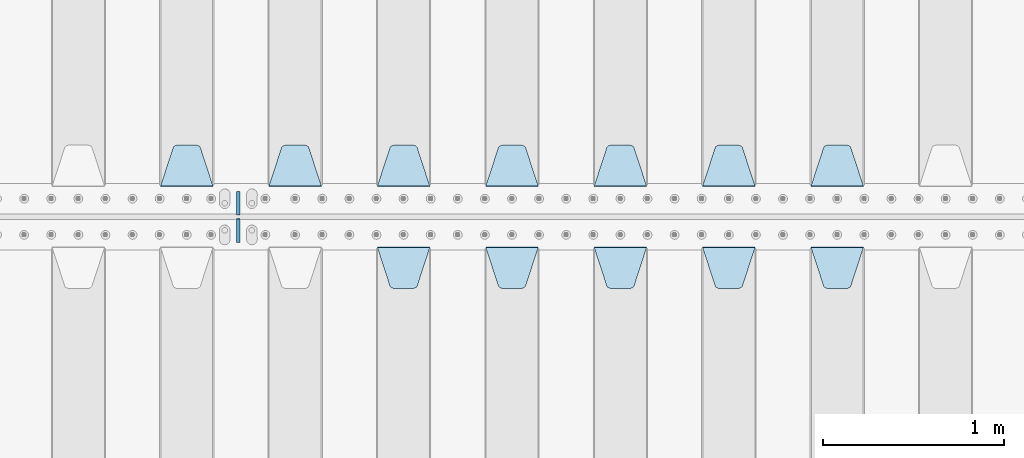
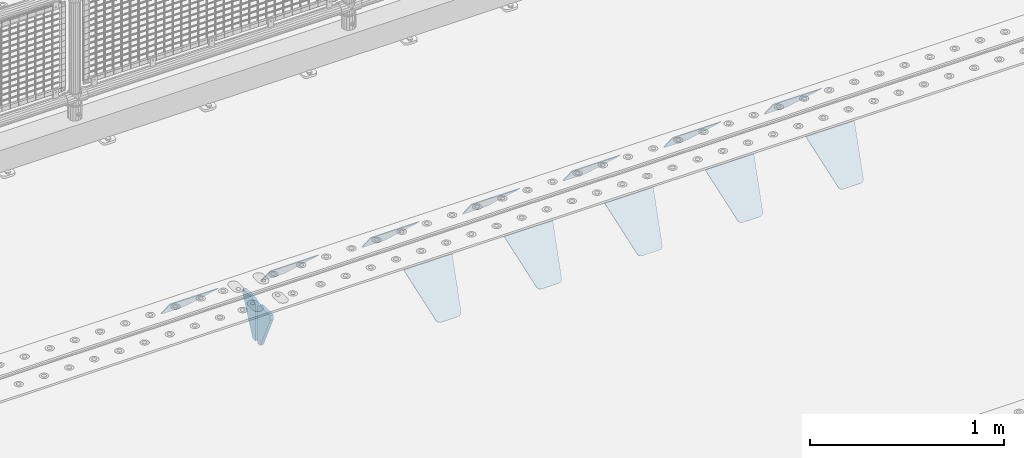
# One storey, part 226 of 270: 14 plates.
"""IFC2X3 building model written with IfcOpenShell, lengths in millimetres."""

from ifc_helpers import new_model, si_unit, frame, origin_with_axes, place, context, subcontext, project, spatial, faceted_brep, material, type_object, element, save


model = new_model("IFC2X3")

# Units and contexts
model_context = context("Model", 3, precision=1e-05, world=origin_with_axes())
body_context = subcontext(model_context, "Body", "Model", "MODEL_VIEW")
ifc_project = project(units=[si_unit("LENGTHUNIT", "METRE", prefix="MILLI"), si_unit("AREAUNIT", "SQUARE_METRE"), si_unit("VOLUMEUNIT", "CUBIC_METRE"), si_unit("MASSUNIT", "GRAM", prefix="KILO"), si_unit("TIMEUNIT", "SECOND"), si_unit("PLANEANGLEUNIT", "RADIAN"), si_unit("SOLIDANGLEUNIT", "STERADIAN"), si_unit("THERMODYNAMICTEMPERATUREUNIT", "DEGREE_CELSIUS"), si_unit("LUMINOUSINTENSITYUNIT", "LUMEN")], contexts=[model_context])

# Site, building, storey
site_placement = place(None, origin_with_axes())
site = spatial("IfcSite", under=ifc_project, at=site_placement, CompositionType="ELEMENT")
building_placement = place(site_placement, origin_with_axes())
building = spatial("IfcBuilding", under=site, at=building_placement, Name="Standard", CompositionType="ELEMENT")
storey_placement = place(building_placement, origin_with_axes())
storey = spatial("IfcBuildingStorey", under=building, at=storey_placement, Name="Undefined", CompositionType="ELEMENT", Elevation=0.0)

# Plates
ifc_material = material(Name="STEEL/S355N")
plate_type_1 = type_object("IfcPlateType", PredefinedType="NOTDEFINED")
plate_1_placement = place(storey_placement, frame((10745.0, -17831.767766953, -1.76776695296758), z_axis=(0.0, 0.707106781186547, -0.707106781186548), x_axis=(-1.0, 0.0, 0.0)))
element("IfcPlate", 1, at=plate_1_placement, inside=storey, type_object=plate_type_1, material=ifc_material, context=body_context, shape_type="Brep", body=[
    faceted_brep([(0.0, -2.5, 0.0), (69.345504679477, -2.5, 300.171731424831), (69.345504679477, 2.5, 300.171731424831), (0.0, 2.5, 0.0), (70.9274061199576, -2.5, 304.8974424154), (70.9274061199576, 2.5, 304.8974424154), (73.3818627772307, -2.49999999999818, 309.234538108527), (73.3818627772307, 2.50000000000182, 309.234538108527), (76.6187032999551, -2.5, 313.023683126103), (76.6187032999551, 2.5, 313.023683126103), (80.5190132704993, -2.5, 316.125672595372), (80.5190132704993, 2.50000000000182, 316.125672595372), (84.9395038596849, -2.49999999999818, 318.426546230476), (84.9395038596849, 2.5, 318.426546230476), (89.7177759439219, -2.49999999999818, 319.841774983275), (89.7177759439219, 2.50000000000182, 319.841774983275), (94.678286292652, -2.5, 320.319366455078), (94.678286292652, 2.5, 320.319366455078), (195.321713707348, -2.5, 320.319366455078), (195.321713707348, 2.5, 320.319366455078), (200.282224056078, -2.49999999999818, 319.841774983275), (200.282224056078, 2.50000000000182, 319.841774983275), (205.060496140315, -2.5, 318.426546230476), (205.060496140315, 2.5, 318.426546230476), (209.480986729501, -2.5, 316.12567259537), (209.480986729501, 2.50000000000182, 316.12567259537), (213.381296700045, -2.5, 313.023683126103), (213.381296700045, 2.5, 313.023683126103), (216.618137222769, -2.49999999999818, 309.234538108525), (216.618137222769, 2.50000000000182, 309.234538108527), (219.072593880042, -2.49999999999818, 304.897442415398), (219.072593880042, 2.50000000000182, 304.897442415397), (220.654495320523, -2.5, 300.171731424831), (220.654495320523, 2.5, 300.171731424831), (290.0, -2.49999999999818, 0.0), (290.0, 2.5, 0.0)], [[[0, 1, 2, 3]], [[1, 4, 5, 2]], [[4, 6, 7, 5]], [[6, 8, 9, 7]], [[8, 10, 11, 9]], [[10, 12, 13, 11]], [[12, 14, 15, 13]], [[14, 16, 17, 15]], [[16, 18, 19, 17]], [[18, 20, 21, 19]], [[20, 22, 23, 21]], [[22, 24, 25, 23]], [[24, 26, 27, 25]], [[26, 28, 29, 27]], [[28, 30, 31, 29]], [[30, 32, 33, 31]], [[32, 34, 35, 33]], [[34, 0, 3, 35]], [[5, 7, 9, 11, 13, 15, 17, 19, 21, 23, 25, 27, 29, 31, 33, 35, 3, 2]], [[34, 32, 30, 28, 26, 24, 22, 20, 18, 16, 14, 12, 10, 8, 6, 4, 1, 0]]]),
])
plate_2_placement = place(storey_placement, frame((10145.0, -17831.767766953, -1.76776695296758), z_axis=(0.0, 0.707106781186547, -0.707106781186548), x_axis=(-1.0, 0.0, 0.0)))
element("IfcPlate", 2, at=plate_2_placement, inside=storey, type_object=plate_type_1, material=ifc_material, context=body_context, shape_type="Brep", body=[
    faceted_brep([(0.0, -2.5, 0.0), (69.345504679477, -2.5, 300.171731424831), (69.345504679477, 2.5, 300.171731424831), (0.0, 2.5, 0.0), (70.9274061199576, -2.5, 304.8974424154), (70.9274061199576, 2.5, 304.8974424154), (73.3818627772307, -2.49999999999818, 309.234538108527), (73.3818627772307, 2.50000000000182, 309.234538108527), (76.6187032999551, -2.5, 313.023683126103), (76.6187032999551, 2.5, 313.023683126103), (80.5190132704993, -2.5, 316.125672595372), (80.5190132704993, 2.50000000000182, 316.125672595372), (84.9395038596849, -2.49999999999818, 318.426546230476), (84.9395038596849, 2.5, 318.426546230476), (89.7177759439219, -2.49999999999818, 319.841774983275), (89.7177759439219, 2.50000000000182, 319.841774983275), (94.678286292652, -2.5, 320.319366455078), (94.678286292652, 2.5, 320.319366455078), (195.321713707348, -2.5, 320.319366455078), (195.321713707348, 2.5, 320.319366455078), (200.282224056078, -2.49999999999818, 319.841774983275), (200.282224056078, 2.50000000000182, 319.841774983275), (205.060496140315, -2.5, 318.426546230476), (205.060496140315, 2.5, 318.426546230476), (209.480986729501, -2.5, 316.12567259537), (209.480986729501, 2.50000000000182, 316.12567259537), (213.381296700045, -2.5, 313.023683126103), (213.381296700045, 2.5, 313.023683126103), (216.618137222769, -2.49999999999818, 309.234538108525), (216.618137222769, 2.50000000000182, 309.234538108527), (219.072593880042, -2.49999999999818, 304.897442415398), (219.072593880042, 2.50000000000182, 304.897442415397), (220.654495320523, -2.5, 300.171731424831), (220.654495320523, 2.5, 300.171731424831), (290.0, -2.49999999999818, 0.0), (290.0, 2.5, 0.0)], [[[0, 1, 2, 3]], [[1, 4, 5, 2]], [[4, 6, 7, 5]], [[6, 8, 9, 7]], [[8, 10, 11, 9]], [[10, 12, 13, 11]], [[12, 14, 15, 13]], [[14, 16, 17, 15]], [[16, 18, 19, 17]], [[18, 20, 21, 19]], [[20, 22, 23, 21]], [[22, 24, 25, 23]], [[24, 26, 27, 25]], [[26, 28, 29, 27]], [[28, 30, 31, 29]], [[30, 32, 33, 31]], [[32, 34, 35, 33]], [[34, 0, 3, 35]], [[5, 7, 9, 11, 13, 15, 17, 19, 21, 23, 25, 27, 29, 31, 33, 35, 3, 2]], [[34, 32, 30, 28, 26, 24, 22, 20, 18, 16, 14, 12, 10, 8, 6, 4, 1, 0]]]),
])
plate_3_placement = place(storey_placement, frame((9545.0, -17831.767766953, -1.76776695296758), z_axis=(0.0, 0.707106781186547, -0.707106781186548), x_axis=(-1.0, 0.0, 0.0)))
element("IfcPlate", 3, at=plate_3_placement, inside=storey, type_object=plate_type_1, material=ifc_material, context=body_context, shape_type="Brep", body=[
    faceted_brep([(0.0, -2.5, 0.0), (69.345504679477, -2.5, 300.171731424831), (69.345504679477, 2.5, 300.171731424831), (0.0, 2.5, 0.0), (70.9274061199576, -2.5, 304.8974424154), (70.9274061199576, 2.5, 304.8974424154), (73.3818627772307, -2.49999999999818, 309.234538108527), (73.3818627772307, 2.50000000000182, 309.234538108527), (76.6187032999551, -2.5, 313.023683126103), (76.6187032999551, 2.5, 313.023683126103), (80.5190132704993, -2.5, 316.125672595372), (80.5190132704993, 2.50000000000182, 316.125672595372), (84.9395038596849, -2.49999999999818, 318.426546230476), (84.9395038596849, 2.5, 318.426546230476), (89.7177759439219, -2.49999999999818, 319.841774983275), (89.7177759439219, 2.50000000000182, 319.841774983275), (94.678286292652, -2.5, 320.319366455078), (94.678286292652, 2.5, 320.319366455078), (195.321713707348, -2.5, 320.319366455078), (195.321713707348, 2.5, 320.319366455078), (200.282224056078, -2.49999999999818, 319.841774983275), (200.282224056078, 2.50000000000182, 319.841774983275), (205.060496140315, -2.5, 318.426546230476), (205.060496140315, 2.5, 318.426546230476), (209.480986729501, -2.5, 316.12567259537), (209.480986729501, 2.50000000000182, 316.12567259537), (213.381296700045, -2.5, 313.023683126103), (213.381296700045, 2.5, 313.023683126103), (216.618137222769, -2.49999999999818, 309.234538108525), (216.618137222769, 2.50000000000182, 309.234538108527), (219.072593880042, -2.49999999999818, 304.897442415398), (219.072593880042, 2.50000000000182, 304.897442415397), (220.654495320523, -2.5, 300.171731424831), (220.654495320523, 2.5, 300.171731424831), (290.0, -2.49999999999818, 0.0), (290.0, 2.5, 0.0)], [[[0, 1, 2, 3]], [[1, 4, 5, 2]], [[4, 6, 7, 5]], [[6, 8, 9, 7]], [[8, 10, 11, 9]], [[10, 12, 13, 11]], [[12, 14, 15, 13]], [[14, 16, 17, 15]], [[16, 18, 19, 17]], [[18, 20, 21, 19]], [[20, 22, 23, 21]], [[22, 24, 25, 23]], [[24, 26, 27, 25]], [[26, 28, 29, 27]], [[28, 30, 31, 29]], [[30, 32, 33, 31]], [[32, 34, 35, 33]], [[34, 0, 3, 35]], [[5, 7, 9, 11, 13, 15, 17, 19, 21, 23, 25, 27, 29, 31, 33, 35, 3, 2]], [[34, 32, 30, 28, 26, 24, 22, 20, 18, 16, 14, 12, 10, 8, 6, 4, 1, 0]]]),
])
plate_4_placement = place(storey_placement, frame((8945.0, -17831.767766953, -1.76776695296758), z_axis=(0.0, 0.707106781186547, -0.707106781186548), x_axis=(-1.0, 0.0, 0.0)))
element("IfcPlate", 4, at=plate_4_placement, inside=storey, type_object=plate_type_1, material=ifc_material, context=body_context, shape_type="Brep", body=[
    faceted_brep([(0.0, -2.5, 0.0), (69.345504679477, -2.5, 300.171731424831), (69.345504679477, 2.5, 300.171731424831), (0.0, 2.5, 0.0), (70.9274061199576, -2.5, 304.8974424154), (70.9274061199576, 2.5, 304.8974424154), (73.3818627772307, -2.49999999999818, 309.234538108527), (73.3818627772307, 2.50000000000182, 309.234538108527), (76.6187032999551, -2.5, 313.023683126103), (76.6187032999551, 2.5, 313.023683126103), (80.5190132704993, -2.5, 316.125672595372), (80.5190132704993, 2.50000000000182, 316.125672595372), (84.9395038596849, -2.49999999999818, 318.426546230476), (84.9395038596849, 2.5, 318.426546230476), (89.7177759439219, -2.49999999999818, 319.841774983275), (89.7177759439219, 2.50000000000182, 319.841774983275), (94.678286292652, -2.5, 320.319366455078), (94.678286292652, 2.5, 320.319366455078), (195.321713707348, -2.5, 320.319366455078), (195.321713707348, 2.5, 320.319366455078), (200.282224056078, -2.49999999999818, 319.841774983275), (200.282224056078, 2.50000000000182, 319.841774983275), (205.060496140315, -2.5, 318.426546230476), (205.060496140315, 2.5, 318.426546230476), (209.480986729501, -2.5, 316.12567259537), (209.480986729501, 2.50000000000182, 316.12567259537), (213.381296700045, -2.5, 313.023683126103), (213.381296700045, 2.5, 313.023683126103), (216.618137222769, -2.49999999999818, 309.234538108525), (216.618137222769, 2.50000000000182, 309.234538108527), (219.072593880042, -2.49999999999818, 304.897442415398), (219.072593880042, 2.50000000000182, 304.897442415397), (220.654495320523, -2.5, 300.171731424831), (220.654495320523, 2.5, 300.171731424831), (290.0, -2.49999999999818, 0.0), (290.0, 2.5, 0.0)], [[[0, 1, 2, 3]], [[1, 4, 5, 2]], [[4, 6, 7, 5]], [[6, 8, 9, 7]], [[8, 10, 11, 9]], [[10, 12, 13, 11]], [[12, 14, 15, 13]], [[14, 16, 17, 15]], [[16, 18, 19, 17]], [[18, 20, 21, 19]], [[20, 22, 23, 21]], [[22, 24, 25, 23]], [[24, 26, 27, 25]], [[26, 28, 29, 27]], [[28, 30, 31, 29]], [[30, 32, 33, 31]], [[32, 34, 35, 33]], [[34, 0, 3, 35]], [[5, 7, 9, 11, 13, 15, 17, 19, 21, 23, 25, 27, 29, 31, 33, 35, 3, 2]], [[34, 32, 30, 28, 26, 24, 22, 20, 18, 16, 14, 12, 10, 8, 6, 4, 1, 0]]]),
])
plate_5_placement = place(storey_placement, frame((8345.0, -17831.767766953, -1.76776695296758), z_axis=(0.0, 0.707106781186547, -0.707106781186548), x_axis=(-1.0, 0.0, 0.0)))
element("IfcPlate", 5, at=plate_5_placement, inside=storey, type_object=plate_type_1, material=ifc_material, context=body_context, shape_type="Brep", body=[
    faceted_brep([(0.0, -2.5, 0.0), (69.345504679477, -2.5, 300.171731424831), (69.345504679477, 2.5, 300.171731424831), (0.0, 2.5, 0.0), (70.9274061199576, -2.5, 304.8974424154), (70.9274061199576, 2.5, 304.8974424154), (73.3818627772307, -2.49999999999818, 309.234538108527), (73.3818627772307, 2.50000000000182, 309.234538108527), (76.6187032999551, -2.5, 313.023683126103), (76.6187032999551, 2.5, 313.023683126103), (80.5190132704993, -2.5, 316.125672595372), (80.5190132704993, 2.50000000000182, 316.125672595372), (84.9395038596849, -2.49999999999818, 318.426546230476), (84.9395038596849, 2.5, 318.426546230476), (89.7177759439219, -2.49999999999818, 319.841774983275), (89.7177759439219, 2.50000000000182, 319.841774983275), (94.678286292652, -2.5, 320.319366455078), (94.678286292652, 2.5, 320.319366455078), (195.321713707348, -2.5, 320.319366455078), (195.321713707348, 2.5, 320.319366455078), (200.282224056078, -2.49999999999818, 319.841774983275), (200.282224056078, 2.50000000000182, 319.841774983275), (205.060496140315, -2.5, 318.426546230476), (205.060496140315, 2.5, 318.426546230476), (209.480986729501, -2.5, 316.12567259537), (209.480986729501, 2.50000000000182, 316.12567259537), (213.381296700045, -2.5, 313.023683126103), (213.381296700045, 2.5, 313.023683126103), (216.618137222769, -2.49999999999818, 309.234538108525), (216.618137222769, 2.50000000000182, 309.234538108527), (219.072593880042, -2.49999999999818, 304.897442415398), (219.072593880042, 2.50000000000182, 304.897442415397), (220.654495320523, -2.5, 300.171731424831), (220.654495320523, 2.5, 300.171731424831), (290.0, -2.49999999999818, 0.0), (290.0, 2.5, 0.0)], [[[0, 1, 2, 3]], [[1, 4, 5, 2]], [[4, 6, 7, 5]], [[6, 8, 9, 7]], [[8, 10, 11, 9]], [[10, 12, 13, 11]], [[12, 14, 15, 13]], [[14, 16, 17, 15]], [[16, 18, 19, 17]], [[18, 20, 21, 19]], [[20, 22, 23, 21]], [[22, 24, 25, 23]], [[24, 26, 27, 25]], [[26, 28, 29, 27]], [[28, 30, 31, 29]], [[30, 32, 33, 31]], [[32, 34, 35, 33]], [[34, 0, 3, 35]], [[5, 7, 9, 11, 13, 15, 17, 19, 21, 23, 25, 27, 29, 31, 33, 35, 3, 2]], [[34, 32, 30, 28, 26, 24, 22, 20, 18, 16, 14, 12, 10, 8, 6, 4, 1, 0]]]),
])
plate_6_placement = place(storey_placement, frame((7745.0, -17831.767766953, -1.76776695296758), z_axis=(0.0, 0.707106781186547, -0.707106781186548), x_axis=(-1.0, 0.0, 0.0)))
element("IfcPlate", 6, at=plate_6_placement, inside=storey, type_object=plate_type_1, material=ifc_material, context=body_context, shape_type="Brep", body=[
    faceted_brep([(0.0, -2.5, 0.0), (69.345504679477, -2.5, 300.171731424831), (69.345504679477, 2.5, 300.171731424831), (0.0, 2.5, 0.0), (70.9274061199576, -2.5, 304.8974424154), (70.9274061199576, 2.5, 304.8974424154), (73.3818627772307, -2.49999999999818, 309.234538108527), (73.3818627772307, 2.50000000000182, 309.234538108527), (76.6187032999551, -2.5, 313.023683126103), (76.6187032999551, 2.5, 313.023683126103), (80.5190132704993, -2.5, 316.125672595372), (80.5190132704993, 2.50000000000182, 316.125672595372), (84.9395038596849, -2.49999999999818, 318.426546230476), (84.9395038596849, 2.5, 318.426546230476), (89.7177759439219, -2.49999999999818, 319.841774983275), (89.7177759439219, 2.50000000000182, 319.841774983275), (94.678286292652, -2.5, 320.319366455078), (94.678286292652, 2.5, 320.319366455078), (195.321713707348, -2.5, 320.319366455078), (195.321713707348, 2.5, 320.319366455078), (200.282224056078, -2.49999999999818, 319.841774983275), (200.282224056078, 2.50000000000182, 319.841774983275), (205.060496140315, -2.5, 318.426546230476), (205.060496140315, 2.5, 318.426546230476), (209.480986729501, -2.5, 316.12567259537), (209.480986729501, 2.50000000000182, 316.12567259537), (213.381296700045, -2.5, 313.023683126103), (213.381296700045, 2.5, 313.023683126103), (216.618137222769, -2.49999999999818, 309.234538108525), (216.618137222769, 2.50000000000182, 309.234538108527), (219.072593880042, -2.49999999999818, 304.897442415398), (219.072593880042, 2.50000000000182, 304.897442415397), (220.654495320523, -2.5, 300.171731424831), (220.654495320523, 2.5, 300.171731424831), (290.0, -2.49999999999818, 0.0), (290.0, 2.5, 0.0)], [[[0, 1, 2, 3]], [[1, 4, 5, 2]], [[4, 6, 7, 5]], [[6, 8, 9, 7]], [[8, 10, 11, 9]], [[10, 12, 13, 11]], [[12, 14, 15, 13]], [[14, 16, 17, 15]], [[16, 18, 19, 17]], [[18, 20, 21, 19]], [[20, 22, 23, 21]], [[22, 24, 25, 23]], [[24, 26, 27, 25]], [[26, 28, 29, 27]], [[28, 30, 31, 29]], [[30, 32, 33, 31]], [[32, 34, 35, 33]], [[34, 0, 3, 35]], [[5, 7, 9, 11, 13, 15, 17, 19, 21, 23, 25, 27, 29, 31, 33, 35, 3, 2]], [[34, 32, 30, 28, 26, 24, 22, 20, 18, 16, 14, 12, 10, 8, 6, 4, 1, 0]]]),
])
plate_7_placement = place(storey_placement, frame((7145.0, -17831.767766953, -1.76776695296758), z_axis=(0.0, 0.707106781186547, -0.707106781186548), x_axis=(-1.0, 0.0, 0.0)))
element("IfcPlate", 7, at=plate_7_placement, inside=storey, type_object=plate_type_1, material=ifc_material, context=body_context, shape_type="Brep", body=[
    faceted_brep([(0.0, -2.5, 0.0), (69.345504679477, -2.5, 300.171731424831), (69.345504679477, 2.5, 300.171731424831), (0.0, 2.5, 0.0), (70.9274061199576, -2.5, 304.8974424154), (70.9274061199576, 2.5, 304.8974424154), (73.3818627772307, -2.49999999999818, 309.234538108527), (73.3818627772307, 2.50000000000182, 309.234538108527), (76.6187032999551, -2.5, 313.023683126103), (76.6187032999551, 2.5, 313.023683126103), (80.5190132704993, -2.5, 316.125672595372), (80.5190132704993, 2.50000000000182, 316.125672595372), (84.9395038596849, -2.49999999999818, 318.426546230476), (84.9395038596849, 2.5, 318.426546230476), (89.7177759439219, -2.49999999999818, 319.841774983275), (89.7177759439219, 2.50000000000182, 319.841774983275), (94.678286292652, -2.5, 320.319366455078), (94.678286292652, 2.5, 320.319366455078), (195.321713707348, -2.5, 320.319366455078), (195.321713707348, 2.5, 320.319366455078), (200.282224056078, -2.49999999999818, 319.841774983275), (200.282224056078, 2.50000000000182, 319.841774983275), (205.060496140315, -2.5, 318.426546230476), (205.060496140315, 2.5, 318.426546230476), (209.480986729501, -2.5, 316.12567259537), (209.480986729501, 2.50000000000182, 316.12567259537), (213.381296700045, -2.5, 313.023683126103), (213.381296700045, 2.5, 313.023683126103), (216.618137222769, -2.49999999999818, 309.234538108525), (216.618137222769, 2.50000000000182, 309.234538108527), (219.072593880042, -2.49999999999818, 304.897442415398), (219.072593880042, 2.50000000000182, 304.897442415397), (220.654495320523, -2.5, 300.171731424831), (220.654495320523, 2.5, 300.171731424831), (290.0, -2.49999999999818, 0.0), (290.0, 2.5, 0.0)], [[[0, 1, 2, 3]], [[1, 4, 5, 2]], [[4, 6, 7, 5]], [[6, 8, 9, 7]], [[8, 10, 11, 9]], [[10, 12, 13, 11]], [[12, 14, 15, 13]], [[14, 16, 17, 15]], [[16, 18, 19, 17]], [[18, 20, 21, 19]], [[20, 22, 23, 21]], [[22, 24, 25, 23]], [[24, 26, 27, 25]], [[26, 28, 29, 27]], [[28, 30, 31, 29]], [[30, 32, 33, 31]], [[32, 34, 35, 33]], [[34, 0, 3, 35]], [[5, 7, 9, 11, 13, 15, 17, 19, 21, 23, 25, 27, 29, 31, 33, 35, 3, 2]], [[34, 32, 30, 28, 26, 24, 22, 20, 18, 16, 14, 12, 10, 8, 6, 4, 1, 0]]]),
])
plate_8_placement = place(storey_placement, frame((10455.0, -18168.232233044, -1.76776695296576), z_axis=(0.0, -0.707106781186548, -0.707106781186547), x_axis=(1.0, 0.0, 0.0)))
element("IfcPlate", 8, at=plate_8_placement, inside=storey, type_object=plate_type_1, material=ifc_material, context=body_context, shape_type="Brep", body=[
    faceted_brep([(0.0, -2.5, 0.0), (69.345504679477, -2.5, 300.171731424831), (69.345504679477, 2.5, 300.171731424831), (0.0, 2.5, 0.0), (70.9274061199576, -2.5, 304.8974424154), (70.9274061199576, 2.5, 304.8974424154), (73.3818627772307, -2.49999999999818, 309.234538108527), (73.3818627772307, 2.50000000000182, 309.234538108527), (76.6187032999551, -2.5, 313.023683126103), (76.6187032999551, 2.5, 313.023683126103), (80.5190132704993, -2.5, 316.125672595372), (80.5190132704993, 2.50000000000182, 316.125672595372), (84.9395038596849, -2.49999999999818, 318.426546230476), (84.9395038596849, 2.5, 318.426546230476), (89.7177759439219, -2.49999999999818, 319.841774983275), (89.7177759439219, 2.50000000000182, 319.841774983275), (94.678286292652, -2.5, 320.319366455078), (94.678286292652, 2.5, 320.319366455078), (195.321713707348, -2.5, 320.319366455078), (195.321713707348, 2.5, 320.319366455078), (200.282224056078, -2.49999999999818, 319.841774983275), (200.282224056078, 2.50000000000182, 319.841774983275), (205.060496140315, -2.5, 318.426546230476), (205.060496140315, 2.5, 318.426546230476), (209.480986729501, -2.5, 316.12567259537), (209.480986729501, 2.50000000000182, 316.12567259537), (213.381296700045, -2.5, 313.023683126103), (213.381296700045, 2.5, 313.023683126103), (216.618137222769, -2.49999999999818, 309.234538108525), (216.618137222769, 2.50000000000182, 309.234538108527), (219.072593880042, -2.49999999999818, 304.897442415398), (219.072593880042, 2.50000000000182, 304.897442415397), (220.654495320523, -2.5, 300.171731424831), (220.654495320523, 2.5, 300.171731424831), (290.0, -2.49999999999818, 0.0), (290.0, 2.5, 0.0)], [[[0, 1, 2, 3]], [[1, 4, 5, 2]], [[4, 6, 7, 5]], [[6, 8, 9, 7]], [[8, 10, 11, 9]], [[10, 12, 13, 11]], [[12, 14, 15, 13]], [[14, 16, 17, 15]], [[16, 18, 19, 17]], [[18, 20, 21, 19]], [[20, 22, 23, 21]], [[22, 24, 25, 23]], [[24, 26, 27, 25]], [[26, 28, 29, 27]], [[28, 30, 31, 29]], [[30, 32, 33, 31]], [[32, 34, 35, 33]], [[34, 0, 3, 35]], [[5, 7, 9, 11, 13, 15, 17, 19, 21, 23, 25, 27, 29, 31, 33, 35, 3, 2]], [[34, 32, 30, 28, 26, 24, 22, 20, 18, 16, 14, 12, 10, 8, 6, 4, 1, 0]]]),
])
plate_9_placement = place(storey_placement, frame((9855.0, -18168.232233044, -1.76776695296576), z_axis=(0.0, -0.707106781186548, -0.707106781186547), x_axis=(1.0, 0.0, 0.0)))
element("IfcPlate", 9, at=plate_9_placement, inside=storey, type_object=plate_type_1, material=ifc_material, context=body_context, shape_type="Brep", body=[
    faceted_brep([(0.0, -2.5, 0.0), (69.345504679477, -2.5, 300.171731424831), (69.345504679477, 2.5, 300.171731424831), (0.0, 2.5, 0.0), (70.9274061199576, -2.5, 304.8974424154), (70.9274061199576, 2.5, 304.8974424154), (73.3818627772307, -2.49999999999818, 309.234538108527), (73.3818627772307, 2.50000000000182, 309.234538108527), (76.6187032999551, -2.5, 313.023683126103), (76.6187032999551, 2.5, 313.023683126103), (80.5190132704993, -2.5, 316.125672595372), (80.5190132704993, 2.50000000000182, 316.125672595372), (84.9395038596849, -2.49999999999818, 318.426546230476), (84.9395038596849, 2.5, 318.426546230476), (89.7177759439219, -2.49999999999818, 319.841774983275), (89.7177759439219, 2.50000000000182, 319.841774983275), (94.678286292652, -2.5, 320.319366455078), (94.678286292652, 2.5, 320.319366455078), (195.321713707348, -2.5, 320.319366455078), (195.321713707348, 2.5, 320.319366455078), (200.282224056078, -2.49999999999818, 319.841774983275), (200.282224056078, 2.50000000000182, 319.841774983275), (205.060496140315, -2.5, 318.426546230476), (205.060496140315, 2.5, 318.426546230476), (209.480986729501, -2.5, 316.12567259537), (209.480986729501, 2.50000000000182, 316.12567259537), (213.381296700045, -2.5, 313.023683126103), (213.381296700045, 2.5, 313.023683126103), (216.618137222769, -2.49999999999818, 309.234538108525), (216.618137222769, 2.50000000000182, 309.234538108527), (219.072593880042, -2.49999999999818, 304.897442415398), (219.072593880042, 2.50000000000182, 304.897442415397), (220.654495320523, -2.5, 300.171731424831), (220.654495320523, 2.5, 300.171731424831), (290.0, -2.49999999999818, 0.0), (290.0, 2.5, 0.0)], [[[0, 1, 2, 3]], [[1, 4, 5, 2]], [[4, 6, 7, 5]], [[6, 8, 9, 7]], [[8, 10, 11, 9]], [[10, 12, 13, 11]], [[12, 14, 15, 13]], [[14, 16, 17, 15]], [[16, 18, 19, 17]], [[18, 20, 21, 19]], [[20, 22, 23, 21]], [[22, 24, 25, 23]], [[24, 26, 27, 25]], [[26, 28, 29, 27]], [[28, 30, 31, 29]], [[30, 32, 33, 31]], [[32, 34, 35, 33]], [[34, 0, 3, 35]], [[5, 7, 9, 11, 13, 15, 17, 19, 21, 23, 25, 27, 29, 31, 33, 35, 3, 2]], [[34, 32, 30, 28, 26, 24, 22, 20, 18, 16, 14, 12, 10, 8, 6, 4, 1, 0]]]),
])
plate_10_placement = place(storey_placement, frame((9255.0, -18168.232233044, -1.76776695296576), z_axis=(0.0, -0.707106781186548, -0.707106781186547), x_axis=(1.0, 0.0, 0.0)))
element("IfcPlate", 10, at=plate_10_placement, inside=storey, type_object=plate_type_1, material=ifc_material, context=body_context, shape_type="Brep", body=[
    faceted_brep([(0.0, -2.5, 0.0), (69.345504679477, -2.5, 300.171731424831), (69.345504679477, 2.5, 300.171731424831), (0.0, 2.5, 0.0), (70.9274061199576, -2.5, 304.8974424154), (70.9274061199576, 2.5, 304.8974424154), (73.3818627772307, -2.49999999999818, 309.234538108527), (73.3818627772307, 2.50000000000182, 309.234538108527), (76.6187032999551, -2.5, 313.023683126103), (76.6187032999551, 2.5, 313.023683126103), (80.5190132704993, -2.5, 316.125672595372), (80.5190132704993, 2.50000000000182, 316.125672595372), (84.9395038596849, -2.49999999999818, 318.426546230476), (84.9395038596849, 2.5, 318.426546230476), (89.7177759439219, -2.49999999999818, 319.841774983275), (89.7177759439219, 2.50000000000182, 319.841774983275), (94.678286292652, -2.5, 320.319366455078), (94.678286292652, 2.5, 320.319366455078), (195.321713707348, -2.5, 320.319366455078), (195.321713707348, 2.5, 320.319366455078), (200.282224056078, -2.49999999999818, 319.841774983275), (200.282224056078, 2.50000000000182, 319.841774983275), (205.060496140315, -2.5, 318.426546230476), (205.060496140315, 2.5, 318.426546230476), (209.480986729501, -2.5, 316.12567259537), (209.480986729501, 2.50000000000182, 316.12567259537), (213.381296700045, -2.5, 313.023683126103), (213.381296700045, 2.5, 313.023683126103), (216.618137222769, -2.49999999999818, 309.234538108525), (216.618137222769, 2.50000000000182, 309.234538108527), (219.072593880042, -2.49999999999818, 304.897442415398), (219.072593880042, 2.50000000000182, 304.897442415397), (220.654495320523, -2.5, 300.171731424831), (220.654495320523, 2.5, 300.171731424831), (290.0, -2.49999999999818, 0.0), (290.0, 2.5, 0.0)], [[[0, 1, 2, 3]], [[1, 4, 5, 2]], [[4, 6, 7, 5]], [[6, 8, 9, 7]], [[8, 10, 11, 9]], [[10, 12, 13, 11]], [[12, 14, 15, 13]], [[14, 16, 17, 15]], [[16, 18, 19, 17]], [[18, 20, 21, 19]], [[20, 22, 23, 21]], [[22, 24, 25, 23]], [[24, 26, 27, 25]], [[26, 28, 29, 27]], [[28, 30, 31, 29]], [[30, 32, 33, 31]], [[32, 34, 35, 33]], [[34, 0, 3, 35]], [[5, 7, 9, 11, 13, 15, 17, 19, 21, 23, 25, 27, 29, 31, 33, 35, 3, 2]], [[34, 32, 30, 28, 26, 24, 22, 20, 18, 16, 14, 12, 10, 8, 6, 4, 1, 0]]]),
])
plate_11_placement = place(storey_placement, frame((8655.0, -18168.232233044, -1.76776695296576), z_axis=(0.0, -0.707106781186548, -0.707106781186547), x_axis=(1.0, 0.0, 0.0)))
element("IfcPlate", 11, at=plate_11_placement, inside=storey, type_object=plate_type_1, material=ifc_material, context=body_context, shape_type="Brep", body=[
    faceted_brep([(0.0, -2.5, 0.0), (69.345504679477, -2.5, 300.171731424831), (69.345504679477, 2.5, 300.171731424831), (0.0, 2.5, 0.0), (70.9274061199576, -2.5, 304.8974424154), (70.9274061199576, 2.5, 304.8974424154), (73.3818627772307, -2.49999999999818, 309.234538108527), (73.3818627772307, 2.50000000000182, 309.234538108527), (76.6187032999551, -2.5, 313.023683126103), (76.6187032999551, 2.5, 313.023683126103), (80.5190132704993, -2.5, 316.125672595372), (80.5190132704993, 2.50000000000182, 316.125672595372), (84.9395038596849, -2.49999999999818, 318.426546230476), (84.9395038596849, 2.5, 318.426546230476), (89.7177759439219, -2.49999999999818, 319.841774983275), (89.7177759439219, 2.50000000000182, 319.841774983275), (94.678286292652, -2.5, 320.319366455078), (94.678286292652, 2.5, 320.319366455078), (195.321713707348, -2.5, 320.319366455078), (195.321713707348, 2.5, 320.319366455078), (200.282224056078, -2.49999999999818, 319.841774983275), (200.282224056078, 2.50000000000182, 319.841774983275), (205.060496140315, -2.5, 318.426546230476), (205.060496140315, 2.5, 318.426546230476), (209.480986729501, -2.5, 316.12567259537), (209.480986729501, 2.50000000000182, 316.12567259537), (213.381296700045, -2.5, 313.023683126103), (213.381296700045, 2.5, 313.023683126103), (216.618137222769, -2.49999999999818, 309.234538108525), (216.618137222769, 2.50000000000182, 309.234538108527), (219.072593880042, -2.49999999999818, 304.897442415398), (219.072593880042, 2.50000000000182, 304.897442415397), (220.654495320523, -2.5, 300.171731424831), (220.654495320523, 2.5, 300.171731424831), (290.0, -2.49999999999818, 0.0), (290.0, 2.5, 0.0)], [[[0, 1, 2, 3]], [[1, 4, 5, 2]], [[4, 6, 7, 5]], [[6, 8, 9, 7]], [[8, 10, 11, 9]], [[10, 12, 13, 11]], [[12, 14, 15, 13]], [[14, 16, 17, 15]], [[16, 18, 19, 17]], [[18, 20, 21, 19]], [[20, 22, 23, 21]], [[22, 24, 25, 23]], [[24, 26, 27, 25]], [[26, 28, 29, 27]], [[28, 30, 31, 29]], [[30, 32, 33, 31]], [[32, 34, 35, 33]], [[34, 0, 3, 35]], [[5, 7, 9, 11, 13, 15, 17, 19, 21, 23, 25, 27, 29, 31, 33, 35, 3, 2]], [[34, 32, 30, 28, 26, 24, 22, 20, 18, 16, 14, 12, 10, 8, 6, 4, 1, 0]]]),
])
plate_12_placement = place(storey_placement, frame((8055.0, -18168.232233044, -1.76776695296576), z_axis=(0.0, -0.707106781186548, -0.707106781186547), x_axis=(1.0, 0.0, 0.0)))
element("IfcPlate", 12, at=plate_12_placement, inside=storey, type_object=plate_type_1, material=ifc_material, context=body_context, shape_type="Brep", body=[
    faceted_brep([(0.0, -2.5, 0.0), (69.345504679477, -2.5, 300.171731424831), (69.345504679477, 2.5, 300.171731424831), (0.0, 2.5, 0.0), (70.9274061199576, -2.5, 304.8974424154), (70.9274061199576, 2.5, 304.8974424154), (73.3818627772307, -2.49999999999818, 309.234538108527), (73.3818627772307, 2.50000000000182, 309.234538108527), (76.6187032999551, -2.5, 313.023683126103), (76.6187032999551, 2.5, 313.023683126103), (80.5190132704993, -2.5, 316.125672595372), (80.5190132704993, 2.50000000000182, 316.125672595372), (84.9395038596849, -2.49999999999818, 318.426546230476), (84.9395038596849, 2.5, 318.426546230476), (89.7177759439219, -2.49999999999818, 319.841774983275), (89.7177759439219, 2.50000000000182, 319.841774983275), (94.678286292652, -2.5, 320.319366455078), (94.678286292652, 2.5, 320.319366455078), (195.321713707348, -2.5, 320.319366455078), (195.321713707348, 2.5, 320.319366455078), (200.282224056078, -2.49999999999818, 319.841774983275), (200.282224056078, 2.50000000000182, 319.841774983275), (205.060496140315, -2.5, 318.426546230476), (205.060496140315, 2.5, 318.426546230476), (209.480986729501, -2.5, 316.12567259537), (209.480986729501, 2.50000000000182, 316.12567259537), (213.381296700045, -2.5, 313.023683126103), (213.381296700045, 2.5, 313.023683126103), (216.618137222769, -2.49999999999818, 309.234538108525), (216.618137222769, 2.50000000000182, 309.234538108527), (219.072593880042, -2.49999999999818, 304.897442415398), (219.072593880042, 2.50000000000182, 304.897442415397), (220.654495320523, -2.5, 300.171731424831), (220.654495320523, 2.5, 300.171731424831), (290.0, -2.49999999999818, 0.0), (290.0, 2.5, 0.0)], [[[0, 1, 2, 3]], [[1, 4, 5, 2]], [[4, 6, 7, 5]], [[6, 8, 9, 7]], [[8, 10, 11, 9]], [[10, 12, 13, 11]], [[12, 14, 15, 13]], [[14, 16, 17, 15]], [[16, 18, 19, 17]], [[18, 20, 21, 19]], [[20, 22, 23, 21]], [[22, 24, 25, 23]], [[24, 26, 27, 25]], [[26, 28, 29, 27]], [[28, 30, 31, 29]], [[30, 32, 33, 31]], [[32, 34, 35, 33]], [[34, 0, 3, 35]], [[5, 7, 9, 11, 13, 15, 17, 19, 21, 23, 25, 27, 29, 31, 33, 35, 3, 2]], [[34, 32, 30, 28, 26, 24, 22, 20, 18, 16, 14, 12, 10, 8, 6, 4, 1, 0]]]),
])
plate_type_2 = type_object("IfcPlateType", PredefinedType="NOTDEFINED")
for number, where, z_axis, x_axis in (
    (13, (7285.0, -17858.75, -35.0), (0.0, 0.0, -1.0), (0.0, -1.0, 0.0)),
    (14, (7285.0, -18141.25, -35.0), (0.0, 0.0, -1.0), (0.0, 1.0, 0.0)),
):
    element("IfcPlate", number, at=place(storey_placement, frame(where, z_axis=z_axis, x_axis=x_axis)), inside=storey, type_object=plate_type_2, material=ifc_material, context=body_context, shape_type="Brep", body=[
        faceted_brep([(0.0, -10.0, 0.0), (0.0, -10.0, 30.0), (0.0, 10.0, 30.0), (0.0, 10.0, 0.0), (102.0, -10.0, 250.0), (102.0, 10.0, 250.0), (132.0, -10.0, 250.0), (132.0, 10.0, 250.0), (132.0, -10.0, 30.0), (132.0, 10.0, 30.0), (131.544232590368, -10.0, 24.790554669992), (131.544232590368, 10.0, 24.790554669992), (130.190778623579, -10.0, 19.7393957002299), (130.190778623579, 10.0, 19.7393957002299), (127.980762113533, -10.0, 15.0), (127.980762113533, 10.0, 15.0), (124.98133329357, -10.0, 10.7163717094038), (124.98133329357, 10.0, 10.7163717094038), (121.283628290596, -10.0, 7.01866670643062), (121.283628290596, 10.0, 7.01866670643062), (117.0, -10.0, 4.01923788646684), (117.0, 10.0, 4.01923788646684), (112.260604299769, -10.0, 1.80922137642278), (112.260604299769, 10.0, 1.80922137642278), (107.209445330009, -10.0, 0.455767409633722), (107.209445330009, 10.0, 0.455767409633722), (102.0, -10.0, 0.0), (102.0, 10.0, 0.0)], [[[0, 1, 2, 3]], [[1, 4, 5, 2]], [[4, 6, 7, 5]], [[6, 8, 9, 7]], [[8, 10, 11, 9]], [[10, 12, 13, 11]], [[12, 14, 15, 13]], [[14, 16, 17, 15]], [[16, 18, 19, 17]], [[18, 20, 21, 19]], [[20, 22, 23, 21]], [[22, 24, 25, 23]], [[24, 26, 27, 25]], [[26, 0, 3, 27]], [[5, 7, 9, 11, 13, 15, 17, 19, 21, 23, 25, 27, 3, 2]], [[26, 24, 22, 20, 18, 16, 14, 12, 10, 8, 6, 4, 1, 0]]]),
    ])

save(model, "model.ifc")
